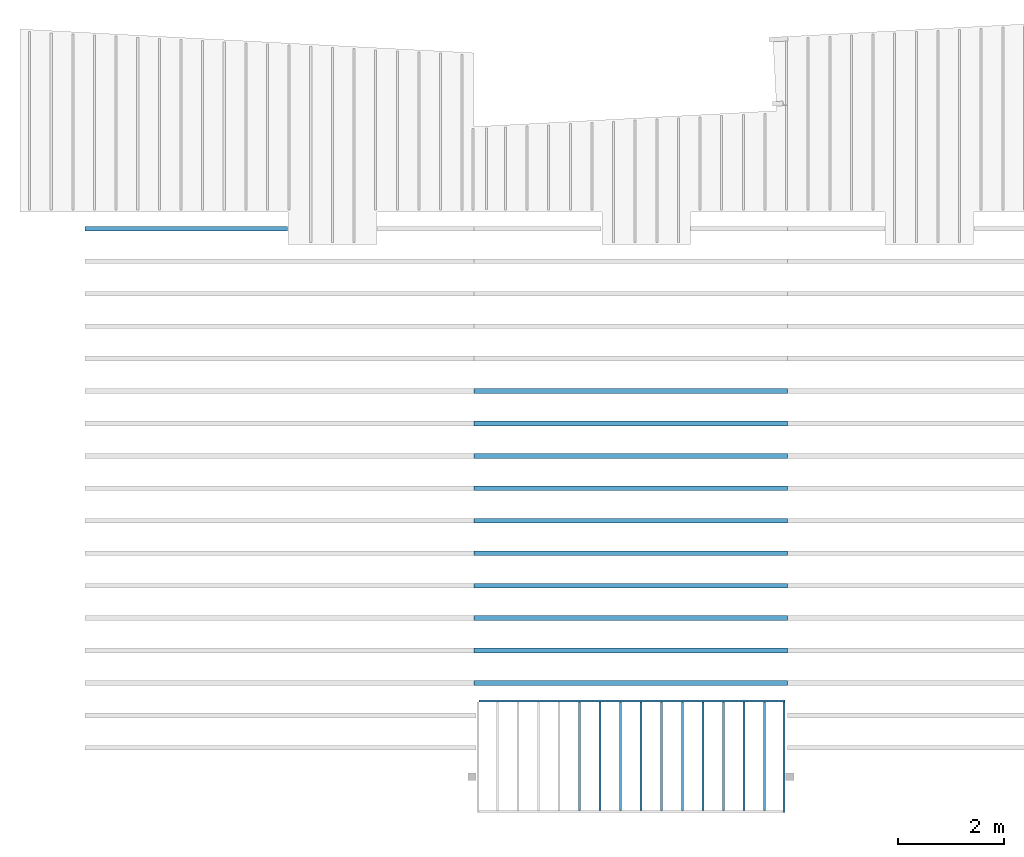
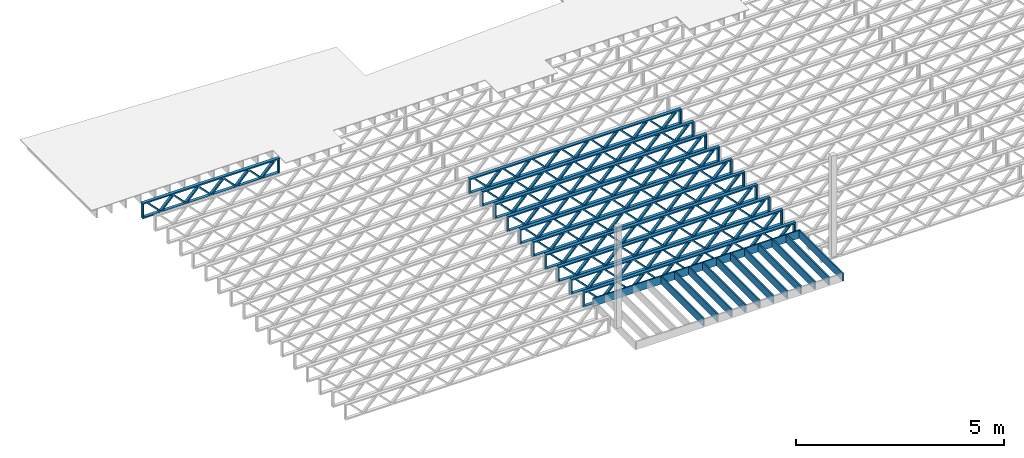
# One storey, part 2 of 12: 23 beams, 3 elements without a shape of their own.
"""IFC4 building model written with IfcOpenShell, lengths in feet."""

from ifc_helpers import new_model, entity, si_unit, converted_unit, derived_unit, direction, frame, frame_2d, origin, origin_2d_with_axis, place, context, subcontext, project, spatial, rectangle, extrude, source, transform, mapped, material, material_profile, profile_set, profile_usage, type_object, type_shapes, element, aggregate, save


model = new_model("IFC4")

# Units and contexts
model_context = context("Model", 3, precision=0.0001, world=origin(), true_north=direction((6.12303176911189e-17, 1.0)))
body_context = subcontext(model_context, "Body", "Model", "MODEL_VIEW")
ifc_project = project(units=[converted_unit("LENGTHUNIT", "FOOT", entity("IfcRatioMeasure", 0.3048), si_unit("LENGTHUNIT", "METRE"), dimensions=[1, 0, 0, 0, 0, 0, 0]), converted_unit("AREAUNIT", "SQUARE FOOT", entity("IfcRatioMeasure", 0.09290304), si_unit("AREAUNIT", "SQUARE_METRE"), dimensions=[2, 0, 0, 0, 0, 0, 0]), converted_unit("VOLUMEUNIT", "CUBIC FOOT", entity("IfcRatioMeasure", 0.028316846592), si_unit("VOLUMEUNIT", "CUBIC_METRE"), dimensions=[3, 0, 0, 0, 0, 0, 0]), converted_unit("PLANEANGLEUNIT", "DEGREE", entity("IfcRatioMeasure", 0.0174532925199433), si_unit("PLANEANGLEUNIT", "RADIAN"), dimensions=[0, 0, 0, 0, 0, 0, 0]), si_unit("MASSUNIT", "GRAM", prefix="KILO"), derived_unit("MASSDENSITYUNIT", [(si_unit("MASSUNIT", "GRAM", prefix="KILO"), 1), (si_unit("LENGTHUNIT", "METRE"), -3)]), derived_unit("MOMENTOFINERTIAUNIT", [(si_unit("LENGTHUNIT", "METRE"), 4)]), si_unit("TIMEUNIT", "SECOND"), si_unit("FREQUENCYUNIT", "HERTZ"), si_unit("THERMODYNAMICTEMPERATUREUNIT", "DEGREE_CELSIUS"), derived_unit("THERMALTRANSMITTANCEUNIT", [(si_unit("MASSUNIT", "GRAM", prefix="KILO"), 1), (si_unit("THERMODYNAMICTEMPERATUREUNIT", "KELVIN"), -1), (si_unit("TIMEUNIT", "SECOND"), -3)]), derived_unit("VOLUMETRICFLOWRATEUNIT", [(si_unit("LENGTHUNIT", "METRE"), 3), (si_unit("TIMEUNIT", "SECOND"), -1)]), si_unit("ELECTRICCURRENTUNIT", "AMPERE"), si_unit("ELECTRICVOLTAGEUNIT", "VOLT"), si_unit("POWERUNIT", "WATT"), si_unit("FORCEUNIT", "NEWTON"), si_unit("ILLUMINANCEUNIT", "LUX"), si_unit("LUMINOUSFLUXUNIT", "LUMEN"), si_unit("LUMINOUSINTENSITYUNIT", "CANDELA"), derived_unit("USERDEFINED", [(si_unit("MASSUNIT", "GRAM", prefix="KILO"), -1), (si_unit("LENGTHUNIT", "METRE"), -2), (si_unit("TIMEUNIT", "SECOND"), 3), (si_unit("LUMINOUSFLUXUNIT", "LUMEN"), 1)]), derived_unit("LINEARVELOCITYUNIT", [(si_unit("LENGTHUNIT", "METRE"), 1), (si_unit("TIMEUNIT", "SECOND"), -1)]), si_unit("PRESSUREUNIT", "PASCAL"), derived_unit("USERDEFINED", [(si_unit("LENGTHUNIT", "METRE"), -2), (si_unit("MASSUNIT", "GRAM", prefix="KILO"), 1), (si_unit("TIMEUNIT", "SECOND"), -2)]), derived_unit("LINEARFORCEUNIT", [(si_unit("MASSUNIT", "GRAM", prefix="KILO"), 1), (si_unit("LENGTHUNIT", "METRE"), 1), (si_unit("TIMEUNIT", "SECOND"), -2), (si_unit("LENGTHUNIT", "METRE"), -1)]), derived_unit("PLANARFORCEUNIT", [(si_unit("MASSUNIT", "GRAM", prefix="KILO"), 1), (si_unit("LENGTHUNIT", "METRE"), 1), (si_unit("TIMEUNIT", "SECOND"), -2), (si_unit("LENGTHUNIT", "METRE"), -2)])], contexts=[model_context])

# Site, building, storey
site_placement = place(None, origin())
site = spatial("IfcSite", under=ifc_project, at=site_placement, CompositionType="ELEMENT")
building_placement = place(site_placement, origin())
building = spatial("IfcBuilding", under=site, at=building_placement, CompositionType="ELEMENT")
storey_placement = place(building_placement, frame((0.0, 0.0, 21.46875)))
storey = spatial("IfcBuildingStorey", under=building, at=storey_placement, Name="3RD FLOOR", CompositionType="ELEMENT", Elevation=21.46875)

# Assembly, beams
assembly_1_placement = place(storey_placement, origin())
assembly_1 = element("IfcElementAssembly", 1, at=assembly_1_placement, inside=storey, Name="Structural Beam System:Structural Framing System", ObjectType="Structural Beam System:Structural Framing System", AssemblyPlace="NOTDEFINED", PredefinedType="BEAM_GRID")
ifc_material_1 = material(Category="Materials")
ifc_material_profile_1 = material_profile(ifc_material_1, rectangle(XDim=0.770833333333333, YDim=0.124999999999994, at=frame_2d((-5.55111512312578e-17, 0.0), x_axis=(1.0, 0.0))))
ifc_profile_set_1 = profile_set([ifc_material_profile_1])
ifc_profile_usage_1 = profile_usage(ifc_profile_set_1, cardinal=8)
beam_type_1 = type_object("IfcBeamType", PredefinedType="BEAM", material=ifc_profile_set_1)
shared_shape_1 = source(origin(), body_context, "Body", "SweptSolid", [
    extrude(rectangle(XDim=0.770833333333333, YDim=0.124999999999994, at=frame_2d((-5.55111512312578e-17, 0.0), x_axis=(1.0, 0.0))), frame((-3.35416666666737, 0.0, 0.0), z_axis=(1.0, 0.0, 0.0), x_axis=(0.0, 0.0, -1.0)), (0.0, 0.0, 1.0), 6.70833333333462),
])
type_shapes(beam_type_1, [shared_shape_1])
beam_1_placement = place(assembly_1_placement, frame((-235.24032967825, 925.341101549317, -0.645833333333474), z_axis=(0.0, 0.0, 1.0), x_axis=(0.0, 1.0, 0.0)))
beam_1 = element("IfcBeam", 2, at=beam_1_placement, type_object=beam_type_1, material=ifc_profile_usage_1, PredefinedType="BEAM", context=body_context, shape_type="MappedRepresentation", body=[
    mapped(shared_shape_1, transform((0.0, 0.0, 0.0), scale=1.0)),
])
ifc_profile_usage_2 = profile_usage(ifc_profile_set_1, cardinal=8)
beam_2_placement = place(assembly_1_placement, frame((-233.973445997692, 925.341101549317, -0.645833333333474), z_axis=(0.0, 0.0, 1.0), x_axis=(0.0, 1.0, 0.0)))
beam_2 = element("IfcBeam", 3, at=beam_2_placement, type_object=beam_type_1, material=ifc_profile_usage_2, PredefinedType="BEAM", context=body_context, shape_type="MappedRepresentation", body=[
    mapped(shared_shape_1, transform((0.0, 0.0, 0.0), scale=1.0)),
])
ifc_profile_usage_3 = profile_usage(ifc_profile_set_1, cardinal=8)
beam_3_placement = place(assembly_1_placement, frame((-232.706562317134, 925.341101549317, -0.645833333333474), z_axis=(0.0, 0.0, 1.0), x_axis=(0.0, 1.0, 0.0)))
beam_3 = element("IfcBeam", 4, at=beam_3_placement, type_object=beam_type_1, material=ifc_profile_usage_3, PredefinedType="BEAM", context=body_context, shape_type="MappedRepresentation", body=[
    mapped(shared_shape_1, transform((0.0, 0.0, 0.0), scale=1.0)),
])
ifc_profile_usage_4 = profile_usage(ifc_profile_set_1, cardinal=8)
beam_4_placement = place(assembly_1_placement, frame((-231.439678636575, 925.341101549318, -0.645833333333435), z_axis=(0.0, 0.0, 1.0), x_axis=(0.0, 1.0, 0.0)))
beam_4 = element("IfcBeam", 5, at=beam_4_placement, type_object=beam_type_1, material=ifc_profile_usage_4, PredefinedType="BEAM", context=body_context, shape_type="MappedRepresentation", body=[
    mapped(shared_shape_1, transform((0.0, 0.0, 0.0), scale=1.0)),
])
ifc_profile_usage_5 = profile_usage(ifc_profile_set_1, cardinal=8)
beam_5_placement = place(assembly_1_placement, frame((-230.172794956017, 925.341101549318, -0.645833333333474), z_axis=(0.0, 0.0, 1.0), x_axis=(0.0, 1.0, 0.0)))
beam_5 = element("IfcBeam", 6, at=beam_5_placement, type_object=beam_type_1, material=ifc_profile_usage_5, PredefinedType="BEAM", context=body_context, shape_type="MappedRepresentation", body=[
    mapped(shared_shape_1, transform((0.0, 0.0, 0.0), scale=1.0)),
])
ifc_profile_usage_6 = profile_usage(ifc_profile_set_1, cardinal=8)
beam_6_placement = place(assembly_1_placement, frame((-228.905911275459, 925.341101549318, -0.645833333333474), z_axis=(0.0, 0.0, 1.0), x_axis=(0.0, 1.0, 0.0)))
beam_6 = element("IfcBeam", 7, at=beam_6_placement, type_object=beam_type_1, material=ifc_profile_usage_6, PredefinedType="BEAM", context=body_context, shape_type="MappedRepresentation", body=[
    mapped(shared_shape_1, transform((0.0, 0.0, 0.0), scale=1.0)),
])
ifc_profile_usage_7 = profile_usage(ifc_profile_set_1, cardinal=8)
beam_7_placement = place(assembly_1_placement, frame((-227.6390275949, 925.341101549318, -0.645833333333474), z_axis=(0.0, 0.0, 1.0), x_axis=(0.0, 1.0, 0.0)))
beam_7 = element("IfcBeam", 8, at=beam_7_placement, type_object=beam_type_1, material=ifc_profile_usage_7, PredefinedType="BEAM", context=body_context, shape_type="MappedRepresentation", body=[
    mapped(shared_shape_1, transform((0.0, 0.0, 0.0), scale=1.0)),
])
ifc_profile_usage_8 = profile_usage(ifc_profile_set_1, cardinal=8)
beam_8_placement = place(assembly_1_placement, frame((-226.372143914342, 925.341101549318, -0.645833333333474), z_axis=(0.0, 0.0, 1.0), x_axis=(0.0, 1.0, 0.0)))
beam_8 = element("IfcBeam", 9, at=beam_8_placement, type_object=beam_type_1, material=ifc_profile_usage_8, PredefinedType="BEAM", context=body_context, shape_type="MappedRepresentation", body=[
    mapped(shared_shape_1, transform((0.0, 0.0, 0.0), scale=1.0)),
])
ifc_profile_usage_9 = profile_usage(ifc_profile_set_1, cardinal=8)
beam_9_placement = place(assembly_1_placement, frame((-225.105260233784, 925.341101549318, -0.645833333333474), z_axis=(0.0, 0.0, 1.0), x_axis=(0.0, 1.0, 0.0)))
beam_9 = element("IfcBeam", 10, at=beam_9_placement, type_object=beam_type_1, material=ifc_profile_usage_9, PredefinedType="BEAM", context=body_context, shape_type="MappedRepresentation", body=[
    mapped(shared_shape_1, transform((0.0, 0.0, 0.0), scale=1.0)),
])
ifc_profile_usage_10 = profile_usage(ifc_profile_set_1, cardinal=8)
beam_10_placement = place(assembly_1_placement, frame((-223.838376553225, 925.341101549319, -0.645833333333474), z_axis=(0.0, 0.0, 1.0), x_axis=(0.0, 1.0, 0.0)))
beam_10 = element("IfcBeam", 11, at=beam_10_placement, type_object=beam_type_1, material=ifc_profile_usage_10, PredefinedType="BEAM", context=body_context, shape_type="MappedRepresentation", body=[
    mapped(shared_shape_1, transform((0.0, 0.0, 0.0), scale=1.0)),
])
aggregate(assembly_1, [beam_1, beam_2, beam_3, beam_4, beam_5, beam_6, beam_7, beam_8, beam_9, beam_10])

# Assembly, beam
assembly_2_placement = place(storey_placement, origin())
assembly_2 = element("IfcElementAssembly", 12, at=assembly_2_placement, inside=storey, Name="Structural Beam System:Structural Framing System", ObjectType="Structural Beam System:Structural Framing System", AssemblyPlace="NOTDEFINED", PredefinedType="BEAM_GRID")
ifc_material_2 = material(Name="WOOD TRUSS", Category="Materials")
ifc_material_profile_2 = material_profile(ifc_material_2, rectangle(XDim=1.73473973950632, YDim=0.125, at=frame_2d((-1.11022302462516e-16, 8.32667268468867e-17), x_axis=(1.0, 0.0))))
ifc_material_profile_3 = material_profile(ifc_material_2, rectangle(XDim=1.73473973950633, YDim=0.125, at=frame_2d((-1.11022302462516e-16, 8.32667268468867e-17), x_axis=(1.0, 0.0))))
ifc_material_profile_4 = material_profile(ifc_material_2, rectangle(XDim=1.73473973950632, YDim=0.125, at=frame_2d((-5.55111512312578e-17, 1.38777878078145e-16), x_axis=(1.0, 0.0))))
ifc_material_profile_5 = material_profile(ifc_material_2, rectangle(XDim=1.73473973950633, YDim=0.125, at=frame_2d((-1.11022302462516e-16, 8.32667268468867e-17), x_axis=(1.0, 0.0))))
ifc_material_profile_6 = material_profile(ifc_material_2, rectangle(XDim=1.73473973950632, YDim=0.125, at=frame_2d((-1.11022302462516e-16, 8.32667268468867e-17), x_axis=(1.0, 0.0))))
ifc_material_profile_7 = material_profile(ifc_material_2, rectangle(XDim=1.73473973950633, YDim=0.125, at=frame_2d((-2.77555756156289e-16, 3.05311331771918e-16), x_axis=(1.0, 0.0))))
ifc_material_profile_8 = material_profile(ifc_material_2, rectangle(XDim=1.73473973950632, YDim=0.124999999999999, at=frame_2d((-3.88578058618805e-16, -2.4980018054066e-16), x_axis=(1.0, 0.0))))
ifc_material_profile_9 = material_profile(ifc_material_2, rectangle(XDim=1.73473973950633, YDim=0.125, at=frame_2d((2.77555756156289e-16, -3.05311331771918e-16), x_axis=(1.0, 0.0))))
ifc_material_profile_10 = material_profile(ifc_material_2, rectangle(XDim=1.73473973950632, YDim=0.124999999999999, at=frame_2d((-1.11022302462516e-16, 8.32667268468867e-17), x_axis=(1.0, 0.0))))
ifc_material_profile_11 = material_profile(ifc_material_2, rectangle(XDim=1.73473973950633, YDim=0.125, at=origin_2d_with_axis()))
ifc_material_profile_12 = material_profile(ifc_material_2, rectangle(XDim=0.124999999999982, YDim=0.291666666666668, at=origin_2d_with_axis()))
ifc_material_profile_13 = material_profile(ifc_material_2, rectangle(XDim=0.124999999999932, YDim=0.291666666666664, at=origin_2d_with_axis()))
ifc_material_profile_14 = material_profile(ifc_material_2, rectangle(XDim=1.25000000000002, YDim=0.29166666666667, at=origin_2d_with_axis()))
ifc_material_profile_15 = material_profile(ifc_material_2, rectangle(XDim=1.25000000000004, YDim=0.291666666666667, at=origin_2d_with_axis()))
ifc_profile_set_2 = profile_set([ifc_material_profile_2, ifc_material_profile_3, ifc_material_profile_4, ifc_material_profile_5, ifc_material_profile_6, ifc_material_profile_7, ifc_material_profile_8, ifc_material_profile_9, ifc_material_profile_10, ifc_material_profile_11, ifc_material_profile_12, ifc_material_profile_13, ifc_material_profile_14, ifc_material_profile_15])
ifc_profile_usage_11 = profile_usage(ifc_profile_set_2, cardinal=8)
beam_type_2 = type_object("IfcBeamType", PredefinedType="BEAM", material=ifc_profile_set_2)
shared_shape_2 = source(origin(), body_context, "Body", "SweptSolid", [
    extrude(rectangle(XDim=1.73473973950632, YDim=0.125, at=frame_2d((-1.11022302462516e-16, 8.32667268468867e-17), x_axis=(1.0, 0.0))), frame((2.91681155651982, -0.145833333333334, 0.0), z_axis=(0.0, 1.0, 0.0), x_axis=(0.693383046997606, 0.0, 0.720569184836762)), (0.0, 0.0, 1.0), 0.291666666666667),
    extrude(rectangle(XDim=1.73473973950633, YDim=0.125, at=frame_2d((-1.11022302462516e-16, 8.32667268468867e-17), x_axis=(1.0, 0.0))), frame((1.66652568284655, -0.145833333333334, 0.0), z_axis=(0.0, 1.0, 0.0), x_axis=(0.69338304699761, 0.0, -0.720569184836758)), (0.0, 0.0, 1.0), 0.291666666666667),
    extrude(rectangle(XDim=1.73473973950632, YDim=0.125, at=frame_2d((-5.55111512312578e-17, 1.38777878078145e-16), x_axis=(1.0, 0.0))), frame((0.625142936836964, -0.145833333333334, 0.0), z_axis=(0.0, 1.0, 0.0), x_axis=(0.693383046997606, 0.0, 0.720569184836762)), (0.0, 0.0, 1.0), 0.291666666666667),
    extrude(rectangle(XDim=1.73473973950633, YDim=0.125, at=frame_2d((-1.11022302462516e-16, 8.32667268468867e-17), x_axis=(1.0, 0.0))), frame((-0.625142936836307, -0.145833333333334, 0.0), z_axis=(0.0, 1.0, 0.0), x_axis=(0.69338304699761, 0.0, -0.720569184836758)), (0.0, 0.0, 1.0), 0.291666666666667),
    extrude(rectangle(XDim=1.73473973950632, YDim=0.125, at=frame_2d((-1.11022302462516e-16, 8.32667268468867e-17), x_axis=(1.0, 0.0))), frame((-1.66652568284589, -0.145833333333334, 0.0), z_axis=(0.0, 1.0, 0.0), x_axis=(0.693383046997606, 0.0, 0.720569184836762)), (0.0, 0.0, 1.0), 0.291666666666667),
    extrude(rectangle(XDim=1.73473973950633, YDim=0.125, at=frame_2d((-2.77555756156289e-16, 3.05311331771918e-16), x_axis=(1.0, 0.0))), frame((-2.91681155651916, -0.145833333333334, 0.0), z_axis=(0.0, 1.0, 0.0), x_axis=(0.69338304699761, 0.0, -0.720569184836758)), (0.0, 0.0, 1.0), 0.291666666666667),
    extrude(rectangle(XDim=1.73473973950632, YDim=0.124999999999999, at=frame_2d((-3.88578058618805e-16, -2.4980018054066e-16), x_axis=(1.0, 0.0))), frame((5.20848017620267, -0.145833333333334, 0.0), z_axis=(0.0, 1.0, 0.0), x_axis=(0.693383046997607, 0.0, 0.720569184836761)), (0.0, 0.0, 1.0), 0.291666666666666),
    extrude(rectangle(XDim=1.73473973950633, YDim=0.125, at=frame_2d((2.77555756156289e-16, -3.05311331771918e-16), x_axis=(1.0, 0.0))), frame((3.9581943025294, -0.145833333333334, 0.0), z_axis=(0.0, 1.0, 0.0), x_axis=(0.69338304699761, 0.0, -0.720569184836758)), (0.0, 0.0, 1.0), 0.291666666666666),
    extrude(rectangle(XDim=1.73473973950632, YDim=0.124999999999999, at=frame_2d((-1.11022302462516e-16, 8.32667268468867e-17), x_axis=(1.0, 0.0))), frame((-3.95819430252874, -0.145833333333334, 0.0), z_axis=(0.0, 1.0, 0.0), x_axis=(0.693383046997606, 0.0, 0.720569184836762)), (0.0, 0.0, 1.0), 0.291666666666667),
    extrude(rectangle(XDim=1.73473973950633, YDim=0.125, at=origin_2d_with_axis()), frame((-5.20848017620202, -0.145833333333334, 0.0), z_axis=(0.0, 1.0, 0.0), x_axis=(0.69338304699761, 0.0, -0.720569184836758)), (0.0, 0.0, 1.0), 0.291666666666666),
    extrude(rectangle(XDim=0.124999999999982, YDim=0.291666666666668, at=origin_2d_with_axis()), frame((-6.25000390603229, 0.0, 0.687500000000054), z_axis=(1.0, 0.0, 0.0), x_axis=(0.0, 0.0, -1.0)), (0.0, 0.0, 1.0), 12.5000078120646),
    extrude(rectangle(XDim=0.124999999999932, YDim=0.291666666666664, at=origin_2d_with_axis()), frame((-6.25000390603208, 0.0, -0.687499999999984), z_axis=(1.0, 0.0, 0.0), x_axis=(0.0, 0.0, -1.0)), (0.0, 0.0, 1.0), 12.5000078120644),
    extrude(rectangle(XDim=1.25000000000002, YDim=0.29166666666667, at=origin_2d_with_axis()), frame((6.12500390603227, 0.0, 0.0), z_axis=(1.0, 0.0, 0.0), x_axis=(0.0, 0.0, -1.0)), (0.0, 0.0, 1.0), 0.12500000000002),
    extrude(rectangle(XDim=1.25000000000004, YDim=0.291666666666667, at=origin_2d_with_axis()), frame((-6.25000390603229, 0.0, 0.0), z_axis=(1.0, 0.0, 0.0), x_axis=(0.0, 0.0, -1.0)), (0.0, 0.0, 1.0), 0.125000000000023),
])
type_shapes(beam_type_2, [shared_shape_2])
beam_11_placement = place(assembly_2_placement, frame((-259.488164391561, 957.861934882651, -0.947916666657854)))
beam_11 = element("IfcBeam", 13, at=beam_11_placement, type_object=beam_type_2, material=ifc_profile_usage_11, PredefinedType="BEAM", context=body_context, shape_type="MappedRepresentation", body=[
    mapped(shared_shape_2, transform((0.0, 0.0, 0.0), scale=1.0)),
])
aggregate(assembly_2, [beam_11])

# Assembly, beams
assembly_3_placement = place(storey_placement, origin())
assembly_3 = element("IfcElementAssembly", 14, at=assembly_3_placement, inside=storey, Name="Structural Beam System:Structural Framing System", ObjectType="Structural Beam System:Structural Framing System", AssemblyPlace="NOTDEFINED", PredefinedType="BEAM_GRID")
ifc_profile_usage_12 = profile_usage(ifc_profile_set_2, cardinal=8)
beam_type_3 = type_object("IfcBeamType", PredefinedType="BEAM", material=ifc_profile_set_2)
shared_shape_3 = source(origin(), body_context, "Body", "SweptSolid", [
    extrude(rectangle(XDim=1.73473973950632, YDim=0.124999999999999, at=frame_2d((5.55111512312578e-16, 7.21644966006352e-16), x_axis=(1.0, 0.0))), frame((5.95847627016997, -0.145833333333334, 0.0), z_axis=(0.0, 1.0, 0.0), x_axis=(0.693383046997606, 0.0, 0.720569184836762)), (0.0, 0.0, 1.0), 0.291666666666667),
    extrude(rectangle(XDim=1.73473973950633, YDim=0.125, at=origin_2d_with_axis()), frame((4.7081903964967, -0.145833333333334, 0.0), z_axis=(0.0, 1.0, 0.0), x_axis=(0.69338304699761, 0.0, -0.720569184836758)), (0.0, 0.0, 1.0), 0.291666666666666),
    extrude(rectangle(XDim=1.73473973950632, YDim=0.125, at=frame_2d((2.22044604925031e-16, 3.88578058618805e-16), x_axis=(1.0, 0.0))), frame((3.29180960350347, -0.145833333333334, 0.0), z_axis=(0.0, 1.0, 0.0), x_axis=(0.693383046997606, 0.0, 0.720569184836762)), (0.0, 0.0, 1.0), 0.291666666666667),
    extrude(rectangle(XDim=1.73473973950633, YDim=0.125, at=frame_2d((1.11022302462516e-16, -8.32667268468867e-17), x_axis=(1.0, 0.0))), frame((2.0415237298302, -0.145833333333334, 0.0), z_axis=(0.0, 1.0, 0.0), x_axis=(0.69338304699761, 0.0, -0.720569184836758)), (0.0, 0.0, 1.0), 0.291666666666667),
    extrude(rectangle(XDim=1.73473973950632, YDim=0.125, at=frame_2d((-5.55111512312578e-17, 1.38777878078145e-16), x_axis=(1.0, 0.0))), frame((0.625142936836964, -0.145833333333334, 0.0), z_axis=(0.0, 1.0, 0.0), x_axis=(0.693383046997606, 0.0, 0.720569184836762)), (0.0, 0.0, 1.0), 0.291666666666667),
    extrude(rectangle(XDim=1.73473973950633, YDim=0.125, at=frame_2d((-1.11022302462516e-16, 8.32667268468867e-17), x_axis=(1.0, 0.0))), frame((-0.625142936836306, -0.145833333333334, 0.0), z_axis=(0.0, 1.0, 0.0), x_axis=(0.69338304699761, 0.0, -0.720569184836758)), (0.0, 0.0, 1.0), 0.291666666666667),
    extrude(rectangle(XDim=1.73473973950632, YDim=0.125, at=frame_2d((-1.11022302462516e-16, 8.32667268468867e-17), x_axis=(1.0, 0.0))), frame((-2.04152372982954, -0.145833333333334, 0.0), z_axis=(0.0, 1.0, 0.0), x_axis=(0.693383046997606, 0.0, 0.720569184836762)), (0.0, 0.0, 1.0), 0.291666666666667),
    extrude(rectangle(XDim=1.73473973950633, YDim=0.125, at=origin_2d_with_axis()), frame((-3.29180960350281, -0.145833333333334, 0.0), z_axis=(0.0, 1.0, 0.0), x_axis=(0.69338304699761, 0.0, -0.720569184836758)), (0.0, 0.0, 1.0), 0.291666666666667),
    extrude(rectangle(XDim=1.73473973950632, YDim=0.124999999999999, at=frame_2d((-1.11022302462516e-16, 8.32667268468867e-17), x_axis=(1.0, 0.0))), frame((-4.70819039649604, -0.145833333333334, 0.0), z_axis=(0.0, 1.0, 0.0), x_axis=(0.693383046997606, 0.0, 0.720569184836762)), (0.0, 0.0, 1.0), 0.291666666666667),
    extrude(rectangle(XDim=1.73473973950633, YDim=0.125, at=frame_2d((-5.55111512312578e-16, 6.38378239159465e-16), x_axis=(1.0, 0.0))), frame((-5.95847627016931, -0.145833333333334, 0.0), z_axis=(0.0, 1.0, 0.0), x_axis=(0.69338304699761, 0.0, -0.720569184836758)), (0.0, 0.0, 1.0), 0.291666666666666),
    extrude(rectangle(XDim=1.73473973950632, YDim=0.125, at=frame_2d((-7.21644966006352e-16, -5.82867087928207e-16), x_axis=(1.0, 0.0))), frame((8.62514293683647, -0.145833333333334, 0.0), z_axis=(0.0, 1.0, 0.0), x_axis=(0.693383046997607, 0.0, 0.720569184836761)), (0.0, 0.0, 1.0), 0.291666666666667),
    extrude(rectangle(XDim=1.73473973950633, YDim=0.125, at=origin_2d_with_axis()), frame((7.3748570631632, -0.145833333333334, 0.0), z_axis=(0.0, 1.0, 0.0), x_axis=(0.69338304699761, 0.0, -0.720569184836758)), (0.0, 0.0, 1.0), 0.291666666666666),
    extrude(rectangle(XDim=1.73473973950632, YDim=0.124999999999999, at=frame_2d((-1.11022302462516e-16, 8.32667268468867e-17), x_axis=(1.0, 0.0))), frame((-7.37485706316255, -0.145833333333334, 0.0), z_axis=(0.0, 1.0, 0.0), x_axis=(0.693383046997606, 0.0, 0.720569184836762)), (0.0, 0.0, 1.0), 0.291666666666667),
    extrude(rectangle(XDim=1.73473973950633, YDim=0.125, at=origin_2d_with_axis()), frame((-8.62514293683582, -0.145833333333334, 0.0), z_axis=(0.0, 1.0, 0.0), x_axis=(0.69338304699761, 0.0, -0.720569184836758)), (0.0, 0.0, 1.0), 0.291666666666666),
    extrude(rectangle(XDim=0.124999999999982, YDim=0.291666666666668, at=origin_2d_with_axis()), frame((-9.66666666666609, 0.0, 0.687500000000054), z_axis=(1.0, 0.0, 0.0), x_axis=(0.0, 0.0, -1.0)), (0.0, 0.0, 1.0), 19.3333333333322),
    extrude(rectangle(XDim=0.124999999999932, YDim=0.291666666666664, at=origin_2d_with_axis()), frame((-9.66666666666588, 0.0, -0.687499999999984), z_axis=(1.0, 0.0, 0.0), x_axis=(0.0, 0.0, -1.0)), (0.0, 0.0, 1.0), 19.333333333332),
    extrude(rectangle(XDim=1.25000000000002, YDim=0.29166666666667, at=origin_2d_with_axis()), frame((9.54166666666607, 0.0, 0.0), z_axis=(1.0, 0.0, 0.0), x_axis=(0.0, 0.0, -1.0)), (0.0, 0.0, 1.0), 0.12500000000002),
    extrude(rectangle(XDim=1.25000000000004, YDim=0.291666666666667, at=origin_2d_with_axis()), frame((-9.66666666666609, 0.0, 0.0), z_axis=(1.0, 0.0, 0.0), x_axis=(0.0, 0.0, -1.0)), (0.0, 0.0, 1.0), 0.125000000000023),
])
type_shapes(beam_type_3, [shared_shape_3])
beam_12_placement = place(assembly_3_placement, frame((-232.071493788724, 947.861934882651, -0.947916666666661)))
beam_12 = element("IfcBeam", 15, at=beam_12_placement, type_object=beam_type_3, material=ifc_profile_usage_12, PredefinedType="BEAM", context=body_context, shape_type="MappedRepresentation", body=[
    mapped(shared_shape_3, transform((0.0, 0.0, 0.0), scale=1.0)),
])
ifc_profile_usage_13 = profile_usage(ifc_profile_set_2, cardinal=8)
beam_13_placement = place(assembly_3_placement, frame((-232.071493788724, 945.861934882651, -0.947916666666661)))
beam_13 = element("IfcBeam", 16, at=beam_13_placement, type_object=beam_type_3, material=ifc_profile_usage_13, PredefinedType="BEAM", context=body_context, shape_type="MappedRepresentation", body=[
    mapped(shared_shape_3, transform((0.0, 0.0, 0.0), scale=1.0)),
])
ifc_profile_usage_14 = profile_usage(ifc_profile_set_2, cardinal=8)
beam_14_placement = place(assembly_3_placement, frame((-232.071493788724, 943.861934882651, -0.947916666666661)))
beam_14 = element("IfcBeam", 17, at=beam_14_placement, type_object=beam_type_3, material=ifc_profile_usage_14, PredefinedType="BEAM", context=body_context, shape_type="MappedRepresentation", body=[
    mapped(shared_shape_3, transform((0.0, 0.0, 0.0), scale=1.0)),
])
ifc_profile_usage_15 = profile_usage(ifc_profile_set_2, cardinal=8)
beam_15_placement = place(assembly_3_placement, frame((-232.071493788724, 941.861934882651, -0.947916666666661)))
beam_15 = element("IfcBeam", 18, at=beam_15_placement, type_object=beam_type_3, material=ifc_profile_usage_15, PredefinedType="BEAM", context=body_context, shape_type="MappedRepresentation", body=[
    mapped(shared_shape_3, transform((0.0, 0.0, 0.0), scale=1.0)),
])
ifc_profile_usage_16 = profile_usage(ifc_profile_set_2, cardinal=8)
beam_16_placement = place(assembly_3_placement, frame((-232.071493788724, 939.861934882651, -0.947916666666661)))
beam_16 = element("IfcBeam", 19, at=beam_16_placement, type_object=beam_type_3, material=ifc_profile_usage_16, PredefinedType="BEAM", context=body_context, shape_type="MappedRepresentation", body=[
    mapped(shared_shape_3, transform((0.0, 0.0, 0.0), scale=1.0)),
])
ifc_profile_usage_17 = profile_usage(ifc_profile_set_2, cardinal=8)
beam_17_placement = place(assembly_3_placement, frame((-232.071493788724, 937.861934882651, -0.947916666666661)))
beam_17 = element("IfcBeam", 20, at=beam_17_placement, type_object=beam_type_3, material=ifc_profile_usage_17, PredefinedType="BEAM", context=body_context, shape_type="MappedRepresentation", body=[
    mapped(shared_shape_3, transform((0.0, 0.0, 0.0), scale=1.0)),
])
ifc_profile_usage_18 = profile_usage(ifc_profile_set_2, cardinal=8)
beam_18_placement = place(assembly_3_placement, frame((-232.071493788724, 935.861934882651, -0.947916666666661)))
beam_18 = element("IfcBeam", 21, at=beam_18_placement, type_object=beam_type_3, material=ifc_profile_usage_18, PredefinedType="BEAM", context=body_context, shape_type="MappedRepresentation", body=[
    mapped(shared_shape_3, transform((0.0, 0.0, 0.0), scale=1.0)),
])
ifc_profile_usage_19 = profile_usage(ifc_profile_set_2, cardinal=8)
beam_19_placement = place(assembly_3_placement, frame((-232.071493788724, 933.861934882651, -0.947916666666661)))
beam_19 = element("IfcBeam", 22, at=beam_19_placement, type_object=beam_type_3, material=ifc_profile_usage_19, PredefinedType="BEAM", context=body_context, shape_type="MappedRepresentation", body=[
    mapped(shared_shape_3, transform((0.0, 0.0, 0.0), scale=1.0)),
])
ifc_profile_usage_20 = profile_usage(ifc_profile_set_2, cardinal=8)
beam_20_placement = place(assembly_3_placement, frame((-232.071493788724, 931.861934882651, -0.947916666666661)))
beam_20 = element("IfcBeam", 23, at=beam_20_placement, type_object=beam_type_3, material=ifc_profile_usage_20, PredefinedType="BEAM", context=body_context, shape_type="MappedRepresentation", body=[
    mapped(shared_shape_3, transform((0.0, 0.0, 0.0), scale=1.0)),
])
ifc_profile_usage_21 = profile_usage(ifc_profile_set_2, cardinal=8)
beam_21_placement = place(assembly_3_placement, frame((-232.071493788724, 929.861934882651, -0.947916666666661)))
beam_21 = element("IfcBeam", 24, at=beam_21_placement, type_object=beam_type_3, material=ifc_profile_usage_21, PredefinedType="BEAM", context=body_context, shape_type="MappedRepresentation", body=[
    mapped(shared_shape_3, transform((0.0, 0.0, 0.0), scale=1.0)),
])
aggregate(assembly_3, [beam_12, beam_13, beam_14, beam_15, beam_16, beam_17, beam_18, beam_19, beam_20, beam_21])

# Beams
ifc_profile_usage_22 = profile_usage(ifc_profile_set_1, cardinal=8)
beam_type_4 = type_object("IfcBeamType", PredefinedType="BEAM", material=ifc_profile_set_1)
shared_shape_4 = source(origin(), body_context, "Body", "SweptSolid", [
    extrude(rectangle(XDim=0.770833333333333, YDim=0.124999999999994, at=origin_2d_with_axis()), frame((-3.47916666666737, 0.0, 0.0), z_axis=(1.0, 0.0, 0.0), x_axis=(0.0, 0.0, -1.0)), (0.0, 0.0, 1.0), 6.83333333333471),
])
type_shapes(beam_type_4, [shared_shape_4])
beam_22_placement = place(storey_placement, frame((-222.633995849213, 925.341101549319, -0.645833333333513), z_axis=(0.0, 0.0, 1.0), x_axis=(0.0, 1.0, 0.0)))
element("IfcBeam", 25, at=beam_22_placement, inside=storey, type_object=beam_type_4, material=ifc_profile_usage_22, PredefinedType="BEAM", context=body_context, shape_type="MappedRepresentation", body=[
    mapped(shared_shape_4, transform((0.0, 0.0, 0.0), scale=1.0)),
])
ifc_profile_usage_23 = profile_usage(ifc_profile_set_1, cardinal=8)
beam_type_5 = type_object("IfcBeamType", PredefinedType="BEAM", material=ifc_profile_set_1)
shared_shape_5 = source(origin(), body_context, "Body", "SweptSolid", [
    extrude(rectangle(XDim=0.770833333333333, YDim=0.124999999999994, at=origin_2d_with_axis()), frame((-9.49999887751909, 0.0, 0.0), z_axis=(1.0, 0.0, 0.0), x_axis=(0.0, 0.0, -1.0)), (0.0, 0.0, 1.0), 18.8749977550383),
])
type_shapes(beam_type_5, [shared_shape_5])
beam_23_placement = place(storey_placement, frame((-232.071494726732, 928.757768215985, -0.645833333333506), z_axis=(0.0, 0.0, 1.0), x_axis=(-1.0, 0.0, 0.0)))
element("IfcBeam", 26, at=beam_23_placement, inside=storey, type_object=beam_type_5, material=ifc_profile_usage_23, PredefinedType="BEAM", context=body_context, shape_type="MappedRepresentation", body=[
    mapped(shared_shape_5, transform((0.0, 0.0, 0.0), scale=1.0)),
])

save(model, "model.ifc")
